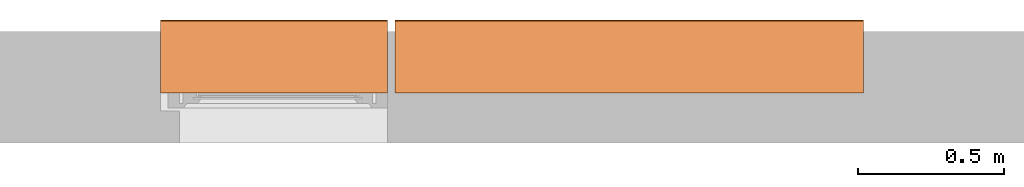
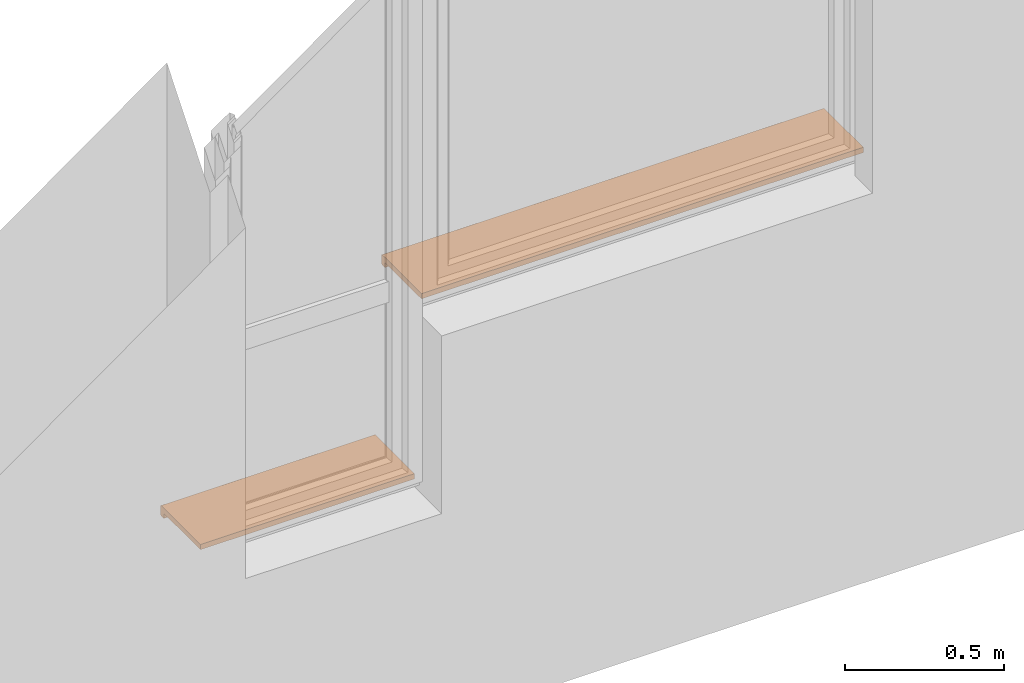
# One storey, part 4 of 4: 2 proxies.
"""IFC2X3 building model written with IfcOpenShell, lengths in millimetres."""

from ifc_helpers import new_model, entity, si_unit, converted_unit, derived_unit, direction, frame, frame_2d, origin, place, context, subcontext, project, spatial, polyline, circle_curve, parameter, trimmed, segment, composite_curve, outline, extrude, source, transform, mapped, material, type_object, type_shapes, element, save


model = new_model("IFC2X3")

# Units and contexts
model_context = context("Model", 3, precision=0.01, world=origin(), true_north=direction((6.12303176911189e-17, 1.0)))
context_of_model = context(None, 3, precision=0.01, world=origin(), true_north=direction((6.12303176911189e-17, 1.0)))
body_context = subcontext(model_context, "Body", "Model", "MODEL_VIEW")
ifc_project = project(units=[si_unit("LENGTHUNIT", "METRE", prefix="MILLI"), si_unit("AREAUNIT", "SQUARE_METRE"), si_unit("VOLUMEUNIT", "CUBIC_METRE"), converted_unit("PLANEANGLEUNIT", "DEGREE", entity("IfcRatioMeasure", 0.0174532925199433), si_unit("PLANEANGLEUNIT", "RADIAN"), dimensions=[0, 0, 0, 0, 0, 0, 0]), si_unit("MASSUNIT", "GRAM", prefix="KILO"), si_unit("TIMEUNIT", "SECOND"), si_unit("FREQUENCYUNIT", "HERTZ"), si_unit("THERMODYNAMICTEMPERATUREUNIT", "DEGREE_CELSIUS"), derived_unit("THERMALTRANSMITTANCEUNIT", [(si_unit("MASSUNIT", "GRAM", prefix="KILO"), 1), (si_unit("THERMODYNAMICTEMPERATUREUNIT", "KELVIN"), -1), (si_unit("TIMEUNIT", "SECOND"), -3)]), derived_unit("VOLUMETRICFLOWRATEUNIT", [(si_unit("LENGTHUNIT", "METRE"), 3), (si_unit("TIMEUNIT", "SECOND"), -1)]), si_unit("ELECTRICCURRENTUNIT", "AMPERE"), si_unit("ELECTRICVOLTAGEUNIT", "VOLT"), si_unit("POWERUNIT", "WATT"), si_unit("FORCEUNIT", "NEWTON", prefix="KILO"), si_unit("ILLUMINANCEUNIT", "LUX"), si_unit("LUMINOUSFLUXUNIT", "LUMEN"), si_unit("LUMINOUSINTENSITYUNIT", "CANDELA"), si_unit("PRESSUREUNIT", "PASCAL")], contexts=[model_context, context_of_model])

# Site, building, storey
site_placement = place(None, origin())
site = spatial("IfcSite", under=ifc_project, at=site_placement, CompositionType="ELEMENT")
building_placement = place(site_placement, origin())
building = spatial("IfcBuilding", under=site, at=building_placement, CompositionType="ELEMENT")
storey_placement = place(building_placement, origin())
storey = spatial("IfcBuildingStorey", under=building, at=storey_placement, CompositionType="ELEMENT", Elevation=0.0)

# Proxies
ifc_material = material()
building_element_proxy_type_1 = type_object("IfcBuildingElementProxyType", PredefinedType="NOTDEFINED", material=ifc_material)
shared_shape_1 = source(origin(), body_context, "Body", "SweptSolid", [
    extrude(outline(composite_curve([segment(trimmed(circle_curve(frame_2d((-63.7499999999991, 15.0), x_axis=(1.0, 0.0)), 5.0), [parameter(89.9999999999997)], [parameter(179.999999999998)], True, "PARAMETER"), True, "CONTINUOUS"), segment(polyline([(-68.7499999999991, 15.0), (-68.7500000000002, -15.0)]), True, "CONTINUOUS"), segment(trimmed(circle_curve(frame_2d((-63.7499999999991, -15.0), x_axis=(1.0, 0.0)), 5.0), [parameter(179.999999999998)], [parameter(270.000000000003)], True, "PARAMETER"), True, "CONTINUOUS"), segment(polyline([(-63.7499999999989, -20.0), (-48.749999999999, -20.0)]), True, "CONTINUOUS"), segment(polyline([(-48.749999999999, -20.0), (-48.749999999999, 0.0)]), True, "CONTINUOUS"), segment(polyline([(-48.749999999999, 0.0), (181.249999999997, 0.0)]), True, "CONTINUOUS"), segment(polyline([(181.249999999997, 0.0), (181.249999999997, 20.0)]), True, "CONTINUOUS"), segment(polyline([(181.249999999997, 20.0), (-63.7499999999991, 20.0)]), True, "CONTINUOUS")], self_intersect=False)), frame((-800.0, -181.249999999996, 10.0), z_axis=(1.0, 0.0, 0.0), x_axis=(0.0, 1.0, 0.0)), (0.0, 0.0, 1.0), 1600.0),
])
type_shapes(building_element_proxy_type_1, [shared_shape_1])
proxy_1_placement = place(storey_placement, frame((-15179.8270290102, 12523.5585138251, 1500.0), z_axis=(0.0, 0.0, 1.0), x_axis=(-1.0, 0.0, 0.0)))
element("IfcBuildingElementProxy", 1, at=proxy_1_placement, inside=storey, type_object=building_element_proxy_type_1, material=ifc_material, context=body_context, shape_type="MappedRepresentation", body=[
    mapped(shared_shape_1, transform((0.0, 0.0, 0.0), scale=1.0)),
])
building_element_proxy_type_2 = type_object("IfcBuildingElementProxyType", PredefinedType="NOTDEFINED", material=ifc_material)
shared_shape_2 = source(origin(), body_context, "Body", "SweptSolid", [
    extrude(outline(composite_curve([segment(trimmed(circle_curve(frame_2d((-63.7499999999991, 15.0), x_axis=(1.0, 0.0)), 5.0), [parameter(89.9999999999997)], [parameter(179.999999999998)], True, "PARAMETER"), True, "CONTINUOUS"), segment(polyline([(-68.7499999999991, 15.0), (-68.7500000000002, -15.0)]), True, "CONTINUOUS"), segment(trimmed(circle_curve(frame_2d((-63.7499999999991, -15.0), x_axis=(1.0, 0.0)), 5.0), [parameter(179.999999999998)], [parameter(270.000000000003)], True, "PARAMETER"), True, "CONTINUOUS"), segment(polyline([(-63.7499999999989, -20.0), (-48.749999999999, -20.0)]), True, "CONTINUOUS"), segment(polyline([(-48.749999999999, -20.0), (-48.749999999999, 0.0)]), True, "CONTINUOUS"), segment(polyline([(-48.749999999999, 0.0), (181.249999999997, 0.0)]), True, "CONTINUOUS"), segment(polyline([(181.249999999997, 0.0), (181.249999999997, 20.0)]), True, "CONTINUOUS"), segment(polyline([(181.249999999997, 20.0), (-63.7499999999991, 20.0)]), True, "CONTINUOUS")], self_intersect=False)), frame((-387.5, -181.249999999997, 10.0), z_axis=(1.0, 0.0, 0.0), x_axis=(0.0, 1.0, 0.0)), (0.0, 0.0, 1.0), 775.0),
])
type_shapes(building_element_proxy_type_2, [shared_shape_2])
proxy_2_placement = place(storey_placement, frame((-16392.3270290103, 12523.5585138251, 820.0), z_axis=(0.0, 0.0, 1.0), x_axis=(-1.0, 0.0, 0.0)))
element("IfcBuildingElementProxy", 2, at=proxy_2_placement, inside=storey, type_object=building_element_proxy_type_2, material=ifc_material, context=body_context, shape_type="MappedRepresentation", body=[
    mapped(shared_shape_2, transform((0.0, 0.0, 0.0), scale=1.0)),
])

save(model, "model.ifc")
